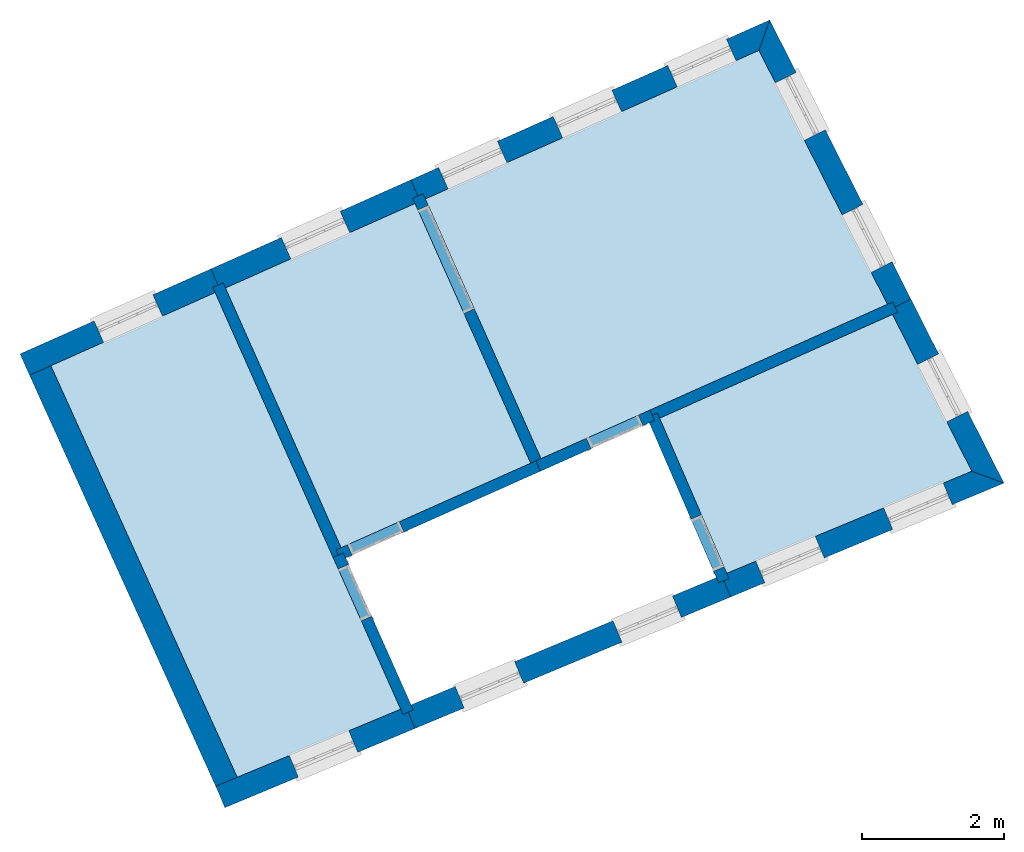
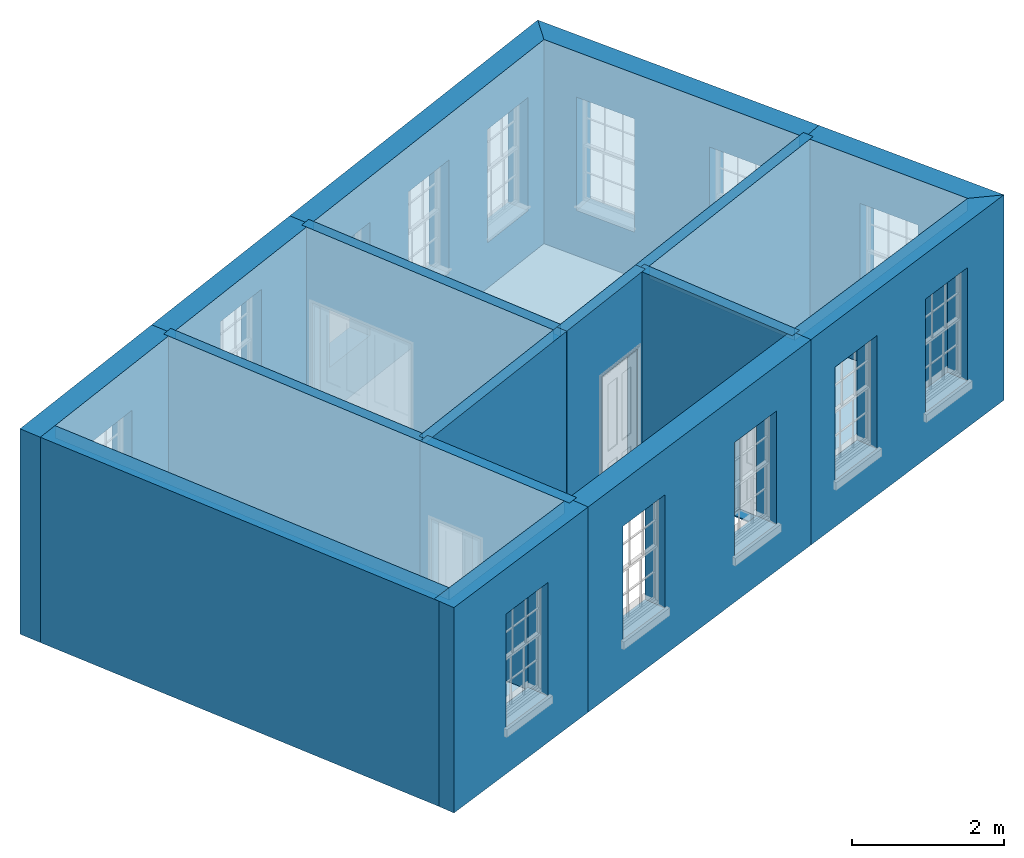
# One storey, part 1 of 8: 16 walls, 8 slabs, 18 openings.
"""IFC2X3 building model written with IfcOpenShell, lengths in metres."""

import ifcopenshell
import ifcopenshell.guid

model = None  # the IFC model being written
_history = None  # IfcOwnerHistory: only IFC2X3 demands one
_inside = {}  # id of a spatial element -> (the spatial element, [elements in it])
_under = {}  # id of a project, library or spatial element -> (it, [spatial elements below it])
_declared = {}  # id of a project -> (the project, [libraries it declares])
_typed = {}  # id of a type object -> (the type object, [elements of that type])
_made_of = {}  # id of a material, layer set ... -> (it, [elements and type objects made of it])


def new_model(schema):
    """Start an empty IFC model of exactly this schema.

    Asked for "IFC4X3", IfcOpenShell would pick the latest addendum, in which some entities
    have other attributes; the version numbers below select the first issue.
    IFC2X3 requires an IfcOwnerHistory on every rooted entity: one is made here for all.
    """
    global model, _history
    if schema == "IFC4X3":
        model = ifcopenshell.file(schema_version=(4, 3, 0, 0))
    else:
        model = ifcopenshell.file(schema=schema)
    _inside.clear()
    _under.clear()
    _declared.clear()
    _typed.clear()
    _made_of.clear()
    _history = None
    if model.schema == "IFC2X3":
        org = make("IfcOrganization", Name="unknown")
        user = make(
            "IfcPersonAndOrganization",
            ThePerson=make("IfcPerson", FamilyName="unknown"),
            TheOrganization=org,
        )
        app = make(
            "IfcApplication",
            ApplicationDeveloper=org,
            Version="unknown",
            ApplicationFullName="unknown",
            ApplicationIdentifier="unknown",
        )
        _history = make(
            "IfcOwnerHistory",
            OwningUser=user,
            OwningApplication=app,
            ChangeAction="ADDED",
            CreationDate=0,
        )
    return model


def make(cls, **values):
    """One entity of the class cls with the attributes given. An attribute that is None is left unset."""
    return model.create_entity(
        cls, **{name: value for name, value in values.items() if value is not None}
    )


def rooted(cls, **values):
    """An entity with a GlobalId (a new one), such as an element, a storey or a relation."""
    return make(cls, GlobalId=ifcopenshell.guid.new(), OwnerHistory=_history, **values)


def si_unit(unit_type, name, prefix=None):
    """IfcSIUnit, for example si_unit("LENGTHUNIT", "METRE", prefix="MILLI")."""
    return make("IfcSIUnit", UnitType=unit_type, Prefix=prefix, Name=name)


def assignment(units):
    """IfcUnitAssignment: the units of a project."""
    return None if units is None else make("IfcUnitAssignment", Units=units)


def point(xyz):
    """IfcCartesianPoint."""
    return None if xyz is None else make("IfcCartesianPoint", Coordinates=xyz)


def direction(xyz):
    """IfcDirection."""
    return None if xyz is None else make("IfcDirection", DirectionRatios=xyz)


def frame(location, z_axis=None, x_axis=None):
    """IfcAxis2Placement3D, a coordinate frame: its origin and axes. An axis left out is left unset."""
    return make(
        "IfcAxis2Placement3D",
        Location=point(location),
        Axis=direction(z_axis),
        RefDirection=direction(x_axis),
    )


def origin():
    """The frame at (0, 0, 0) with its axes left unset."""
    return frame((0.0, 0.0, 0.0))


def place(relative_to, where):
    """IfcLocalPlacement: puts the frame where relative to a parent placement (None: the world)."""
    return make(
        "IfcLocalPlacement", PlacementRelTo=relative_to, RelativePlacement=where
    )


def context(
    kind, dimensions, precision=None, world=None, true_north=None, identifier=None
):
    """IfcGeometricRepresentationContext, for example the 3D "Model" context."""
    return make(
        "IfcGeometricRepresentationContext",
        ContextIdentifier=identifier,
        ContextType=kind,
        CoordinateSpaceDimension=dimensions,
        Precision=precision,
        WorldCoordinateSystem=world,
        TrueNorth=true_north,
    )


def subcontext(parent, identifier, kind, view, scale=None):
    """IfcGeometricRepresentationSubContext, for example "Body" below "Model"."""
    return make(
        "IfcGeometricRepresentationSubContext",
        ContextIdentifier=identifier,
        ContextType=kind,
        ParentContext=parent,
        TargetScale=scale,
        TargetView=view,
    )


def project(units=None, contexts=None):
    """IfcProject with its units and contexts."""
    return rooted(
        "IfcProject",
        Name="project",
        RepresentationContexts=contexts,
        UnitsInContext=assignment(units),
    )


def spatial(cls, under=None, at=None, **own):
    """A site, building, storey or space (cls), placed at a placement, below another one or the project."""
    s = rooted(cls, ObjectPlacement=at, **own)
    if under is not None:
        _under.setdefault(under.id(), (under, []))[1].append(s)
    return s


def polyline(points):
    """IfcPolyline through the points."""
    return make("IfcPolyline", Points=[point(p) for p in points])


def outline(outer, holes=None, kind="AREA"):
    """IfcArbitraryClosedProfileDef: a profile drawn as a closed curve; with holes, ...WithVoids."""
    if holes is None:
        return make("IfcArbitraryClosedProfileDef", ProfileType=kind, OuterCurve=outer)
    return make(
        "IfcArbitraryProfileDefWithVoids",
        ProfileType=kind,
        OuterCurve=outer,
        InnerCurves=holes,
    )


def extrude(swept, where, along, depth):
    """IfcExtrudedAreaSolid: the profile swept, set in the frame where, extruded along a direction by depth."""
    return make(
        "IfcExtrudedAreaSolid",
        SweptArea=swept,
        Position=where,
        ExtrudedDirection=direction(along),
        Depth=depth,
    )


def shape(context_of_items, identifier, shape_type, items):
    """IfcShapeRepresentation: the items that make up one representation, for example the "Body"."""
    return make(
        "IfcShapeRepresentation",
        ContextOfItems=context_of_items,
        RepresentationIdentifier=identifier,
        RepresentationType=shape_type,
        Items=items,
    )


def material(Name=None, Category=None):
    """IfcMaterial."""
    return make("IfcMaterial", Name=Name, Category=Category)


def layer(
    of_material, thickness, ventilated=None, Name=None, Category=None, Priority=None
):
    """IfcMaterialLayer: one layer of a wall or slab, of a material (None: an air gap)."""
    return make(
        "IfcMaterialLayer",
        Material=of_material,
        LayerThickness=thickness,
        IsVentilated=ventilated,
        Name=Name,
        Category=Category,
        Priority=Priority,
    )


def layer_set(layers, Name=None):
    """IfcMaterialLayerSet."""
    return make("IfcMaterialLayerSet", MaterialLayers=layers, LayerSetName=Name)


def layer_usage(for_layer_set, set_direction, sense, offset, extent=None):
    """IfcMaterialLayerSetUsage: how a layer set lies in its element."""
    return make(
        "IfcMaterialLayerSetUsage",
        ForLayerSet=for_layer_set,
        LayerSetDirection=set_direction,
        DirectionSense=sense,
        OffsetFromReferenceLine=offset,
        ReferenceExtent=extent,
    )


def made_of(thing, what):
    """Note that an element or type object is made of a material, layer set ...; save() writes the relation."""
    if what is not None:
        _made_of.setdefault(what.id(), (what, []))[1].append(thing)
    return thing


def element(
    cls,
    number,
    at=None,
    inside=None,
    cuts=None,
    type_object=None,
    material=None,
    context=None,
    identifier="Body",
    shape_type=None,
    held_by="IfcProductDefinitionShape",
    body=None,
    shapes=None,
    **own,
):
    """One element of the class cls, such as IfcWall. Its Tag is "e" and its number.

    at: its placement. inside: the storey or other place that contains it. cuts: it is an
    opening in that element (IfcRelVoidsElement). A single representation is given by context,
    identifier, shape_type and body (its items); several are given by shapes. held_by: the class
    of the entity that holds the representations. save() writes the other relations.
    """
    e = rooted(cls, Tag="e%d" % number, ObjectPlacement=at, **own)
    if body is not None:
        shapes = [shape(context, identifier, shape_type, body)]
    if shapes is not None:
        e.Representation = make(held_by, Representations=shapes)
    if inside is not None:
        _inside.setdefault(inside.id(), (inside, []))[1].append(e)
    if cuts is not None:
        rooted(
            "IfcRelVoidsElement", RelatingBuildingElement=cuts, RelatedOpeningElement=e
        )
    if type_object is not None:
        _typed.setdefault(type_object.id(), (type_object, []))[1].append(e)
    return made_of(e, material)


def aggregate(whole, parts):
    """IfcRelAggregates: a whole, such as a stair, and the parts it consists of."""
    return rooted("IfcRelAggregates", RelatingObject=whole, RelatedObjects=parts)


def save(model, path):
    """Write the relations noted so far, then the file.

    IfcRelAggregates (storeys below a building ...), IfcRelContainedInSpatialStructure (elements
    in a storey), IfcRelDefinesByType, IfcRelAssociatesMaterial and IfcRelDeclares: one each for
    every whole, place, type object, material and project.
    """
    for whole, parts in _under.values():
        aggregate(whole, parts)
    for where, things in _inside.values():
        rooted(
            "IfcRelContainedInSpatialStructure",
            RelatedElements=things,
            RelatingStructure=where,
        )
    for kind, things in _typed.values():
        rooted("IfcRelDefinesByType", RelatedObjects=things, RelatingType=kind)
    for what, things in _made_of.values():
        rooted("IfcRelAssociatesMaterial", RelatedObjects=things, RelatingMaterial=what)
    for by, libraries in _declared.values():
        rooted("IfcRelDeclares", RelatingContext=by, RelatedDefinitions=libraries)
    model.write(path)


model = new_model("IFC2X3")

# Units and contexts
model_context = context("Model", 3, world=origin())
body_context = subcontext(model_context, "Body", "Model", "MODEL_VIEW")
ifc_project = project(units=[si_unit("PLANEANGLEUNIT", "RADIAN"), si_unit("MASSUNIT", "GRAM", prefix="KILO"), si_unit("FORCEUNIT", "NEWTON", prefix="KILO"), si_unit("LENGTHUNIT", "METRE")], contexts=[model_context])

# Site, building, storey
site_placement = place(None, origin())
site = spatial("IfcSite", under=ifc_project, at=site_placement, CompositionType="ELEMENT")
building_placement = place(None, origin())
building = spatial("IfcBuilding", under=site, at=building_placement, Name="Building plot-1", CompositionType="ELEMENT")
storey_placement = place(None, frame((0.0, 0.0, 5.15)))
storey = spatial("IfcBuildingStorey", under=building, at=storey_placement, Name="Floor 1", CompositionType="ELEMENT", Elevation=5.15)

# Slabs
slab_1_placement = place(storey_placement, frame((0.0, 0.0, 3.1)))
element("IfcSlab", 1, at=slab_1_placement, inside=storey, Name="Slab", ObjectType="Slab", PredefinedType="FLOOR", context=body_context, shape_type="SweptSolid", body=[
    extrude(outline(polyline([(24.5167658048641, 48.572552210313), (26.1510006181193, 44.903045310535), (31.0458649225511, 47.0829996943095), (29.2305507452247, 50.6718619165302), (24.5167658048641, 48.572552210313)])), origin(), (0.0, 0.0, 1.0), 0.2),
])
slab_2_placement = place(storey_placement, frame((0.0, 0.0, 3.1)))
element("IfcSlab", 2, at=slab_2_placement, inside=storey, Name="Slab", ObjectType="Slab", PredefinedType="FLOOR", context=body_context, shape_type="SweptSolid", body=[
    extrude(outline(polyline([(28.7763704736843, 43.2819856054629), (32.2388263663203, 44.7245240587508), (31.1181708300863, 46.9400514690174), (27.827102328502, 45.4743562502888), (28.7763704736843, 43.2819856054629)])), origin(), (0.0, 0.0, 1.0), 0.2),
])
slab_3_placement = place(storey_placement, frame((0.0, 0.0, 3.1)))
element("IfcSlab", 3, at=slab_3_placement, inside=storey, Name="Slab", ObjectType="Slab", PredefinedType="FLOOR", context=body_context, shape_type="SweptSolid", body=[
    extrude(outline(polyline([(24.3706054157099, 48.50745888775), (21.6915727140128, 47.3143371341903), (23.325807527268, 43.6448302344123), (26.0048402289651, 44.837951987972), (24.3706054157099, 48.50745888775)])), origin(), (0.0, 0.0, 1.0), 0.2),
])
slab_4_placement = place(storey_placement, frame((0.0, 0.0, 3.1)))
element("IfcSlab", 4, at=slab_4_placement, inside=storey, Name="Slab", ObjectType="Slab", PredefinedType="FLOOR", context=body_context, shape_type="SweptSolid", body=[
    extrude(outline(polyline([(21.8581063270403, 40.3996782574434), (24.1674210791987, 41.3617916919622), (21.5454123248586, 47.2492438116273), (19.2242660267251, 46.2155087102442), (21.8581063270403, 40.3996782574434)])), origin(), (0.0, 0.0, 1.0), 0.2),
])
slab_5_placement = place(storey_placement, origin())
element("IfcSlab", 5, at=slab_5_placement, inside=storey, Name="Slab", ObjectType="Slab", PredefinedType="FLOOR", context=body_context, shape_type="SweptSolid", body=[
    extrude(outline(polyline([(24.5167658048641, 48.572552210313), (26.1510006181193, 44.903045310535), (31.0458649225511, 47.0829996943095), (29.2305507452247, 50.6718619165302), (24.5167658048641, 48.572552210313)])), origin(), (0.0, 0.0, 1.0), 0.02),
])
slab_6_placement = place(storey_placement, origin())
element("IfcSlab", 6, at=slab_6_placement, inside=storey, Name="Slab", ObjectType="Slab", PredefinedType="FLOOR", context=body_context, shape_type="SweptSolid", body=[
    extrude(outline(polyline([(28.7763704736843, 43.2819856054629), (32.2388263663203, 44.7245240587508), (31.1181708300863, 46.9400514690174), (27.827102328502, 45.4743562502888), (28.7763704736843, 43.2819856054629)])), origin(), (0.0, 0.0, 1.0), 0.02),
])
slab_7_placement = place(storey_placement, origin())
element("IfcSlab", 7, at=slab_7_placement, inside=storey, Name="Slab", ObjectType="Slab", PredefinedType="FLOOR", context=body_context, shape_type="SweptSolid", body=[
    extrude(outline(polyline([(24.3706054157099, 48.50745888775), (21.6915727140128, 47.3143371341903), (23.325807527268, 43.6448302344123), (26.0048402289651, 44.837951987972), (24.3706054157099, 48.50745888775)])), origin(), (0.0, 0.0, 1.0), 0.02),
])
slab_8_placement = place(storey_placement, origin())
element("IfcSlab", 8, at=slab_8_placement, inside=storey, Name="Slab", ObjectType="Slab", PredefinedType="FLOOR", context=body_context, shape_type="SweptSolid", body=[
    extrude(outline(polyline([(21.8581063270403, 40.3996782574434), (24.1674210791987, 41.3617916919622), (21.5454123248586, 47.2492438116273), (19.2242660267251, 46.2155087102442), (21.8581063270403, 40.3996782574434)])), origin(), (0.0, 0.0, 1.0), 0.02),
])

# Wall, opening
ifc_material_1 = material(Name="Masonry")
ifc_layer_1 = layer(ifc_material_1, 0.33, ventilated=False)
ifc_layer_set_1 = layer_set([ifc_layer_1], Name="My Wall")
ifc_layer_usage_1 = layer_usage(ifc_layer_set_1, "AXIS2", "NEGATIVE", 0.08)
wall_1_placement = place(storey_placement, origin())
wall_1 = element("IfcWallStandardCase", 9, at=wall_1_placement, inside=storey, material=ifc_layer_usage_1, Name="exterior", context=body_context, shape_type="SweptSolid", body=[
    extrude(outline(polyline([(21.5557040167118, 40.2736905266135), (21.6826157364214, 39.9690704100743), (24.3699915253352, 41.0886927342715), (24.2430798056257, 41.3933128508107), (21.5557040167118, 40.2736905266135)])), origin(), (0.0, 0.0, 1.0), 3.3),
])
opening_1_placement = place(storey_placement, frame((0.0, 0.0, 0.75)))
element("IfcOpeningElement", 10, at=opening_1_placement, cuts=wall_1, Name="Opening", ObjectType="Opening", context=body_context, shape_type="SweptSolid", body=[
    extrude(outline(polyline([(22.7216835143391, 40.4019698524633), (23.5616965629775, 40.7519385340866), (23.434784843268, 41.0565586506259), (22.5947717946295, 40.7065899690026), (22.7216835143391, 40.4019698524633)])), origin(), (0.0, 0.0, 1.0), 1.82),
])

# Wall, openings
wall_2_placement = place(storey_placement, origin())
wall_2 = element("IfcWallStandardCase", 11, at=wall_2_placement, inside=storey, material=ifc_layer_usage_1, Name="exterior", context=body_context, shape_type="SweptSolid", body=[
    extrude(outline(polyline([(24.2430798056257, 41.3933128508107), (24.3699915253352, 41.0886927342715), (28.8304515653399, 42.947022580652), (28.7035398456304, 43.2516426971912), (24.2430798056257, 41.3933128508107)])), origin(), (0.0, 0.0, 1.0), 3.3),
])
opening_2_placement = place(storey_placement, frame((0.0, 0.0, 0.75)))
element("IfcOpeningElement", 12, at=opening_2_placement, cuts=wall_2, Name="Opening", ObjectType="Opening", context=body_context, shape_type="SweptSolid", body=[
    extrude(outline(polyline([(25.0651000110172, 41.378290855055), (25.9051130596556, 41.7282595366783), (25.7782013399461, 42.0328796532175), (24.9381882913076, 41.6829109715942), (25.0651000110172, 41.378290855055)])), origin(), (0.0, 0.0, 1.0), 1.82),
])
opening_3_placement = place(storey_placement, frame((0.0, 0.0, 0.75)))
element("IfcOpeningElement", 13, at=opening_3_placement, cuts=wall_2, Name="Opening", ObjectType="Opening", context=body_context, shape_type="SweptSolid", body=[
    extrude(outline(polyline([(27.2953300310195, 42.3074557782452), (28.135343079658, 42.6574244598685), (28.0084313599484, 42.9620445764077), (27.16841831131, 42.6120758947844), (27.2953300310195, 42.3074557782452)])), origin(), (0.0, 0.0, 1.0), 1.82),
])

wall_3_placement = place(storey_placement, origin())
wall_3 = element("IfcWallStandardCase", 14, at=wall_3_placement, inside=storey, material=ifc_layer_usage_1, Name="exterior", context=body_context, shape_type="SweptSolid", body=[
    extrude(outline(polyline([(28.7035398456304, 43.2516426971912), (28.8304515653399, 42.947022580652), (32.693625357205, 44.5565092916169), (32.2388263663203, 44.7245240587508), (28.7035398456304, 43.2516426971912)])), origin(), (0.0, 0.0, 1.0), 3.3),
])
opening_4_placement = place(storey_placement, frame((0.0, 0.0, 0.75)))
element("IfcOpeningElement", 15, at=opening_4_placement, cuts=wall_3, Name="Opening", ObjectType="Opening", context=body_context, shape_type="SweptSolid", body=[
    extrude(outline(polyline([(29.314138627022, 43.1485376923154), (30.1541516756604, 43.4985063739387), (30.0272399559509, 43.8031264904779), (29.1872269073124, 43.4531578088546), (29.314138627022, 43.1485376923154)])), origin(), (0.0, 0.0, 1.0), 1.82),
])
opening_5_placement = place(storey_placement, frame((0.0, 0.0, 0.75)))
element("IfcOpeningElement", 16, at=opening_5_placement, cuts=wall_3, Name="Opening", ObjectType="Opening", context=body_context, shape_type="SweptSolid", body=[
    extrude(outline(polyline([(31.1215257990245, 43.9015365972656), (31.9615388476629, 44.2515052788889), (31.8346271279534, 44.5561253954281), (30.994614079315, 44.2061567138048), (31.1215257990245, 43.9015365972656)])), origin(), (0.0, 0.0, 1.0), 1.82),
])

# Wall, opening
wall_4_placement = place(storey_placement, origin())
wall_4 = element("IfcWallStandardCase", 17, at=wall_4_placement, inside=storey, material=ifc_layer_usage_1, Name="exterior", context=body_context, shape_type="SweptSolid", body=[
    extrude(outline(polyline([(32.2388263663203, 44.7245240587508), (32.693625357205, 44.5565092916169), (31.3782721430408, 47.1569525196551), (31.083799749939, 47.0080028311663), (32.2388263663203, 44.7245240587508)])), origin(), (0.0, 0.0, 1.0), 3.3),
])
opening_6_placement = place(storey_placement, frame((0.0, 0.0, 0.75)))
element("IfcOpeningElement", 18, at=opening_6_placement, cuts=wall_4, Name="Opening", ObjectType="Opening", context=body_context, shape_type="SweptSolid", body=[
    extrude(outline(polyline([(32.180589003273, 45.5707782331861), (31.7698489531979, 46.3828081656789), (31.4753765600961, 46.2338584771901), (31.8861166101712, 45.4218285446973), (32.180589003273, 45.5707782331861)])), origin(), (0.0, 0.0, 1.0), 1.82),
])

# Wall, openings
wall_5_placement = place(storey_placement, origin())
wall_5 = element("IfcWallStandardCase", 19, at=wall_5_placement, inside=storey, material=ifc_layer_usage_1, Name="exterior", context=body_context, shape_type="SweptSolid", body=[
    extrude(outline(polyline([(31.083799749939, 47.0080028311663), (31.3782721430408, 47.1569525196551), (29.383242432719, 51.1011109738831), (29.2305507452247, 50.6718619165302), (31.083799749939, 47.0080028311663)])), origin(), (0.0, 0.0, 1.0), 3.3),
])
opening_7_placement = place(storey_placement, frame((0.0, 0.0, 0.75)))
element("IfcOpeningElement", 20, at=opening_7_placement, cuts=wall_5, Name="Opening", ObjectType="Opening", context=body_context, shape_type="SweptSolid", body=[
    extrude(outline(polyline([(31.111737146863, 47.6838901652868), (30.7009970967879, 48.4959200977797), (30.4065247036861, 48.3469704092909), (30.8172647537612, 47.5349404767981), (31.111737146863, 47.6838901652868)])), origin(), (0.0, 0.0, 1.0), 1.82),
])
opening_8_placement = place(storey_placement, frame((0.0, 0.0, 0.75)))
element("IfcOpeningElement", 21, at=opening_8_placement, cuts=wall_5, Name="Opening", ObjectType="Opening", context=body_context, shape_type="SweptSolid", body=[
    extrude(outline(polyline([(30.1679271044322, 49.5497953890432), (29.7571870543571, 50.3618253215361), (29.4627146612553, 50.2128756330473), (29.8734547113304, 49.4008457005545), (30.1679271044322, 49.5497953890432)])), origin(), (0.0, 0.0, 1.0), 1.82),
])

wall_6_placement = place(storey_placement, origin())
wall_6 = element("IfcWallStandardCase", 22, at=wall_6_placement, inside=storey, material=ifc_layer_usage_1, Name="exterior", context=body_context, shape_type="SweptSolid", body=[
    extrude(outline(polyline([(29.2305507452247, 50.6718619165302), (29.383242432719, 51.1011109738831), (24.3094306325007, 48.841461351662), (24.443685610287, 48.5400055490315), (29.2305507452247, 50.6718619165302)])), origin(), (0.0, 0.0, 1.0), 3.3),
])
opening_9_placement = place(storey_placement, frame((0.0, 0.0, 0.75)))
element("IfcOpeningElement", 23, at=opening_9_placement, cuts=wall_6, Name="Opening", ObjectType="Opening", context=body_context, shape_type="SweptSolid", body=[
    extrude(outline(polyline([(28.7720975415616, 50.8289342797521), (27.9408103282473, 50.4587160076747), (28.0750653060336, 50.1572602050442), (28.906352519348, 50.5274784771217), (28.7720975415616, 50.8289342797521)])), origin(), (0.0, 0.0, 1.0), 1.82),
])
opening_10_placement = place(storey_placement, frame((0.0, 0.0, 0.75)))
element("IfcOpeningElement", 24, at=opening_10_placement, cuts=wall_6, Name="Opening", ObjectType="Opening", context=body_context, shape_type="SweptSolid", body=[
    extrude(outline(polyline([(27.1532882206001, 50.1079887629316), (26.3220010072858, 49.7377704908541), (26.4562559850721, 49.4363146882236), (27.2875431983865, 49.8065329603011), (27.1532882206001, 50.1079887629316)])), origin(), (0.0, 0.0, 1.0), 1.82),
])
opening_11_placement = place(storey_placement, frame((0.0, 0.0, 0.75)))
element("IfcOpeningElement", 25, at=opening_11_placement, cuts=wall_6, Name="Opening", ObjectType="Opening", context=body_context, shape_type="SweptSolid", body=[
    extrude(outline(polyline([(25.5344788996386, 49.387043246111), (24.7031916863243, 49.0168249740335), (24.8374466641106, 48.7153691714031), (25.668733877425, 49.0855874434805), (25.5344788996386, 49.387043246111)])), origin(), (0.0, 0.0, 1.0), 1.82),
])

# Wall, opening
wall_7_placement = place(storey_placement, origin())
wall_7 = element("IfcWallStandardCase", 26, at=wall_7_placement, inside=storey, material=ifc_layer_usage_1, Name="exterior", context=body_context, shape_type="SweptSolid", body=[
    extrude(outline(polyline([(24.443685610287, 48.5400055490315), (24.3094306325007, 48.841461351662), (21.4842375416494, 47.5832462755393), (21.6184925194357, 47.2817904729088), (24.443685610287, 48.5400055490315)])), origin(), (0.0, 0.0, 1.0), 3.3),
])
opening_12_placement = place(storey_placement, frame((0.0, 0.0, 1.05)))
element("IfcOpeningElement", 27, at=opening_12_placement, cuts=wall_7, Name="Opening", ObjectType="Opening", context=body_context, shape_type="SweptSolid", body=[
    extrude(outline(polyline([(23.3124776937322, 48.3974629496394), (22.4811904804179, 48.0272446775619), (22.6154454582042, 47.7257888749314), (23.4467326715186, 48.0960071470089), (23.3124776937322, 48.3974629496394)])), origin(), (0.0, 0.0, 1.0), 1.82),
])

wall_8_placement = place(storey_placement, origin())
wall_8 = element("IfcWallStandardCase", 28, at=wall_8_placement, inside=storey, material=ifc_layer_usage_1, Name="exterior", context=body_context, shape_type="SweptSolid", body=[
    extrude(outline(polyline([(21.6184925194357, 47.2817904729088), (21.4842375416494, 47.5832462755393), (18.7880965575994, 46.3825052555824), (18.9223515353857, 46.0810494529519), (21.6184925194357, 47.2817904729088)])), origin(), (0.0, 0.0, 1.0), 3.3),
])
opening_13_placement = place(storey_placement, frame((0.0, 0.0, 0.75)))
element("IfcOpeningElement", 29, at=opening_13_placement, cuts=wall_8, Name="Opening", ObjectType="Opening", context=body_context, shape_type="SweptSolid", body=[
    extrude(outline(polyline([(20.6659984603083, 47.218839059852), (19.8347112469939, 46.8486207877745), (19.9689662247802, 46.547164985144), (20.8002534380946, 46.9173832572215), (20.6659984603083, 47.218839059852)])), origin(), (0.0, 0.0, 1.0), 1.82),
])

# Walls
wall_9_placement = place(storey_placement, origin())
element("IfcWallStandardCase", 30, at=wall_9_placement, inside=storey, material=ifc_layer_usage_1, Name="party", context=body_context, shape_type="SweptSolid", body=[
    extrude(outline(polyline([(19.1910556078216, 46.2888412374996), (18.8904457144576, 46.1527027344532), (21.5895085420772, 40.1928532382579), (21.8901184354412, 40.3289917413043), (19.1910556078216, 46.2888412374996)])), origin(), (0.0, 0.0, 1.0), 3.3),
])
ifc_material_2 = material(Name="Masonry")
ifc_layer_2 = layer(ifc_material_2, 0.16, ventilated=False)
ifc_layer_set_2 = layer_set([ifc_layer_2], Name="My Wall")
ifc_layer_usage_2 = layer_usage(ifc_layer_set_2, "AXIS2", "NEGATIVE", 0.08)
wall_10_placement = place(storey_placement, origin())
element("IfcWallStandardCase", 31, at=wall_10_placement, inside=storey, material=ifc_layer_usage_2, Name="interior", context=body_context, shape_type="SweptSolid", body=[
    extrude(outline(polyline([(21.6590260527313, 47.3874173287674), (21.5128656635771, 47.3223240062044), (23.2121937993953, 43.5066567172722), (23.3583541885495, 43.5717500398352), (21.6590260527313, 47.3874173287674)])), origin(), (0.0, 0.0, 1.0), 3.3),
])

# Wall, opening
wall_11_placement = place(storey_placement, origin())
wall_11 = element("IfcWallStandardCase", 32, at=wall_11_placement, inside=storey, material=ifc_layer_usage_2, Name="interior", context=body_context, shape_type="SweptSolid", body=[
    extrude(outline(polyline([(24.4842191435826, 48.6456324048901), (24.3380587544284, 48.5805390823271), (26.0373868902466, 44.7648717933949), (26.1835472794008, 44.8299651159579), (24.4842191435826, 48.6456324048901)])), origin(), (0.0, 0.0, 1.0), 3.3),
])
opening_14_placement = place(storey_placement, frame((0.0, 0.0, 0.0199999999999996)))
element("IfcOpeningElement", 33, at=opening_14_placement, cuts=wall_11, Name="Opening", ObjectType="Opening", context=body_context, shape_type="SweptSolid", body=[
    extrude(outline(polyline([(24.4112887423119, 48.4161086445286), (25.0622219679426, 46.9545047529869), (25.2083823570968, 47.0195980755499), (24.557449131466, 48.4812019670917), (24.4112887423119, 48.4161086445286)])), origin(), (0.0, 0.0, 1.0), 2.1),
])

wall_12_placement = place(storey_placement, origin())
wall_12 = element("IfcWallStandardCase", 34, at=wall_12_placement, inside=storey, material=ifc_layer_usage_2, Name="interior", context=body_context, shape_type="SweptSolid", body=[
    extrude(outline(polyline([(23.3583541885495, 43.5717500398352), (23.2121937993953, 43.5066567172722), (24.2007660885539, 41.28691888855), (24.3469264777081, 41.352012211113), (23.3583541885495, 43.5717500398352)])), origin(), (0.0, 0.0, 1.0), 3.3),
])
opening_15_placement = place(storey_placement, frame((0.0, 0.0, 0.0199999999999996)))
element("IfcOpeningElement", 35, at=opening_15_placement, cuts=wall_12, Name="Opening", ObjectType="Opening", context=body_context, shape_type="SweptSolid", body=[
    extrude(outline(polyline([(23.2854237872788, 43.3422262794737), (23.6108904000941, 42.6114243337028), (23.7570507892483, 42.6765176562659), (23.4315841764329, 43.4073196020368), (23.2854237872788, 43.3422262794737)])), origin(), (0.0, 0.0, 1.0), 2.1),
])

wall_13_placement = place(storey_placement, origin())
wall_13 = element("IfcWallStandardCase", 36, at=wall_13_placement, inside=storey, material=ifc_layer_usage_2, Name="interior", context=body_context, shape_type="SweptSolid", body=[
    extrude(outline(polyline([(26.1430137461052, 44.7243382600993), (26.0779204235422, 44.8704986492535), (23.2527273326909, 43.6122835731308), (23.3178206552539, 43.4661231839766), (26.1430137461052, 44.7243382600993)])), origin(), (0.0, 0.0, 1.0), 3.3),
])
opening_16_placement = place(storey_placement, frame((0.0, 0.0, 0.0199999999999996)))
element("IfcOpeningElement", 37, at=opening_16_placement, cuts=wall_13, Name="Opening", ObjectType="Opening", context=body_context, shape_type="SweptSolid", body=[
    extrude(outline(polyline([(24.1479597162602, 44.0109801738296), (23.4171577704893, 43.6855135610142), (23.4822510930524, 43.5393531718601), (24.2130530388233, 43.8648197846754), (24.1479597162602, 44.0109801738296)])), origin(), (0.0, 0.0, 1.0), 2.1),
])

wall_14_placement = place(storey_placement, origin())
wall_14 = element("IfcWallStandardCase", 38, at=wall_14_placement, inside=storey, material=ifc_layer_usage_2, Name="interior", context=body_context, shape_type="SweptSolid", body=[
    extrude(outline(polyline([(27.7956430256276, 45.5470126988155), (27.6488155837474, 45.4834383147375), (28.6608926021956, 43.146008204173), (28.8077200440758, 43.209582588251), (27.7956430256276, 45.5470126988155)])), origin(), (0.0, 0.0, 1.0), 3.3),
])
opening_17_placement = place(storey_placement, frame((0.0, 0.0, 0.0199999999999996)))
element("IfcOpeningElement", 39, at=opening_17_placement, cuts=wall_14, Name="Opening", ObjectType="Opening", context=body_context, shape_type="SweptSolid", body=[
    extrude(outline(polyline([(28.2714994997177, 44.0453262856896), (28.5893714201078, 43.3111890762883), (28.7361988619881, 43.3747634603663), (28.418326941598, 44.1089006697676), (28.2714994997177, 44.0453262856896)])), origin(), (0.0, 0.0, 1.0), 2.1),
])

wall_15_placement = place(storey_placement, origin())
wall_15 = element("IfcWallStandardCase", 40, at=wall_15_placement, inside=storey, material=ifc_layer_usage_2, Name="interior", context=body_context, shape_type="SweptSolid", body=[
    extrude(outline(polyline([(27.754775965969, 45.4421453121994), (27.689682643406, 45.5883057013536), (26.0779204235422, 44.8704986492535), (26.1430137461052, 44.7243382600993), (27.754775965969, 45.4421453121994)])), origin(), (0.0, 0.0, 1.0), 3.3),
])
opening_18_placement = place(storey_placement, frame((0.0, 0.0, 0.0199999999999996)))
element("IfcOpeningElement", 41, at=opening_18_placement, cuts=wall_15, Name="Opening", ObjectType="Opening", context=body_context, shape_type="SweptSolid", body=[
    extrude(outline(polyline([(27.5252522056075, 45.5150757134701), (26.7944502598366, 45.1896091006548), (26.8595435823997, 45.0434487115006), (27.5903455281706, 45.368915324316), (27.5252522056075, 45.5150757134701)])), origin(), (0.0, 0.0, 1.0), 2.1),
])

# Wall
wall_16_placement = place(storey_placement, origin())
element("IfcWallStandardCase", 42, at=wall_16_placement, inside=storey, material=ifc_layer_usage_2, Name="interior", context=body_context, shape_type="SweptSolid", body=[
    extrude(outline(polyline([(27.689682643406, 45.5883057013536), (27.754775965969, 45.4421453121994), (31.1877336580331, 46.9710316519804), (31.1226403354701, 47.1171920411346), (27.689682643406, 45.5883057013536)])), origin(), (0.0, 0.0, 1.0), 3.3),
])

save(model, "model.ifc")
